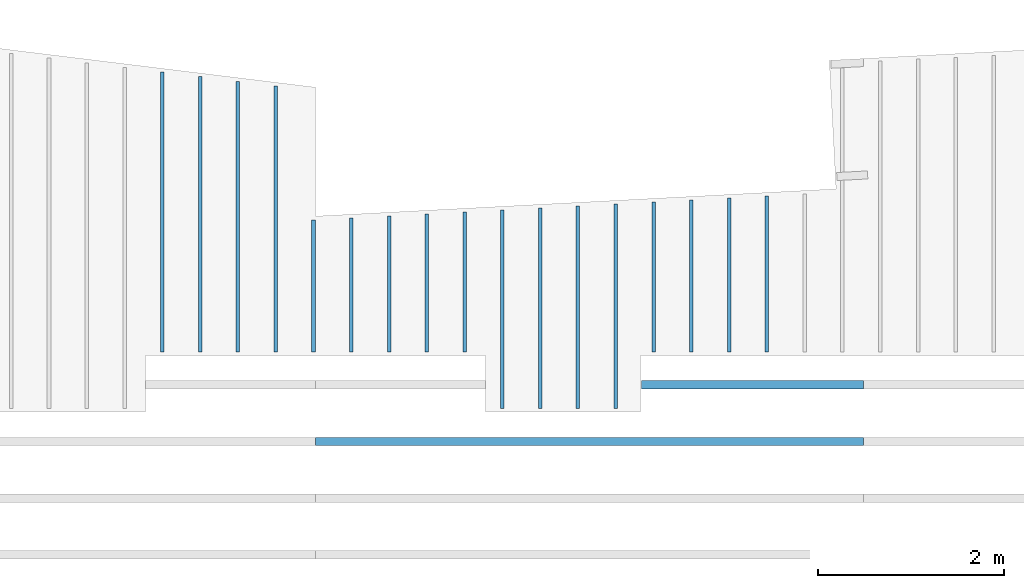
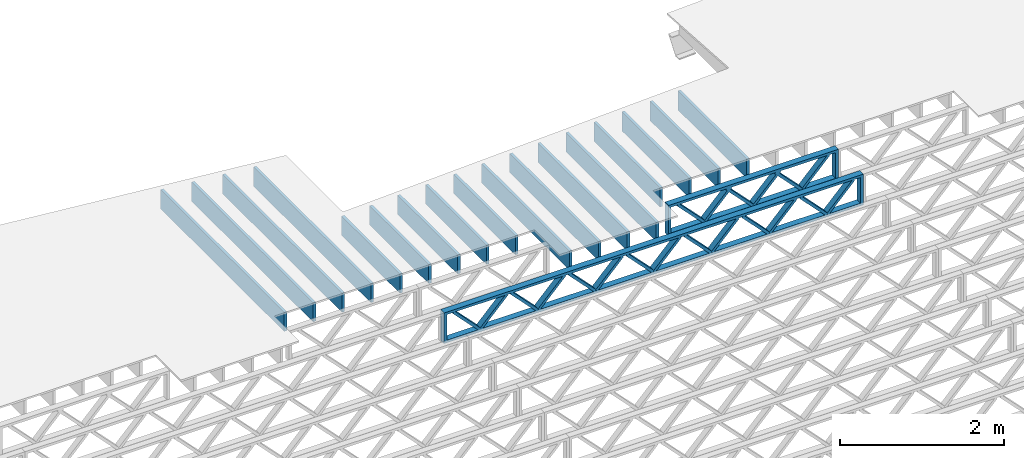
# One storey, part 10 of 13: 19 beams, 2 elements without a shape of their own.
"""IFC4 building model written with IfcOpenShell, lengths in feet."""

from ifc_helpers import new_model, entity, si_unit, converted_unit, derived_unit, direction, frame, frame_2d, origin, origin_2d_with_axis, place, context, subcontext, project, spatial, rectangle, extrude, source, transform, mapped, material, material_profile, profile_set, profile_usage, type_object, type_shapes, element, aggregate, save


model = new_model("IFC4")

# Units and contexts
model_context_1 = context("Model", 3, precision=0.0001, world=origin(), true_north=direction((6.12303176911189e-17, 1.0)))
model_context_2 = context("Model", 3, precision=0.0001, world=origin(), true_north=direction((6.12303176911189e-17, 1.0)))
body_context = subcontext(model_context_2, "Body", "Model", "MODEL_VIEW")
ifc_project = project(units=[converted_unit("LENGTHUNIT", "FOOT", entity("IfcRatioMeasure", 0.3048), si_unit("LENGTHUNIT", "METRE"), dimensions=[1, 0, 0, 0, 0, 0, 0]), converted_unit("AREAUNIT", "SQUARE FOOT", entity("IfcRatioMeasure", 0.09290304), si_unit("AREAUNIT", "SQUARE_METRE"), dimensions=[2, 0, 0, 0, 0, 0, 0]), converted_unit("VOLUMEUNIT", "CUBIC FOOT", entity("IfcRatioMeasure", 0.028316846592), si_unit("VOLUMEUNIT", "CUBIC_METRE"), dimensions=[3, 0, 0, 0, 0, 0, 0]), converted_unit("PLANEANGLEUNIT", "DEGREE", entity("IfcRatioMeasure", 0.0174532925199433), si_unit("PLANEANGLEUNIT", "RADIAN"), dimensions=[0, 0, 0, 0, 0, 0, 0]), si_unit("MASSUNIT", "GRAM", prefix="KILO"), derived_unit("MASSDENSITYUNIT", [(si_unit("MASSUNIT", "GRAM", prefix="KILO"), 1), (si_unit("LENGTHUNIT", "METRE"), -3)]), derived_unit("MOMENTOFINERTIAUNIT", [(si_unit("LENGTHUNIT", "METRE"), 4)]), si_unit("TIMEUNIT", "SECOND"), si_unit("FREQUENCYUNIT", "HERTZ"), si_unit("THERMODYNAMICTEMPERATUREUNIT", "DEGREE_CELSIUS"), derived_unit("THERMALTRANSMITTANCEUNIT", [(si_unit("MASSUNIT", "GRAM", prefix="KILO"), 1), (si_unit("THERMODYNAMICTEMPERATUREUNIT", "KELVIN"), -1), (si_unit("TIMEUNIT", "SECOND"), -3)]), derived_unit("VOLUMETRICFLOWRATEUNIT", [(si_unit("LENGTHUNIT", "METRE"), 3), (si_unit("TIMEUNIT", "SECOND"), -1)]), si_unit("ELECTRICCURRENTUNIT", "AMPERE"), si_unit("ELECTRICVOLTAGEUNIT", "VOLT"), si_unit("POWERUNIT", "WATT"), si_unit("FORCEUNIT", "NEWTON"), si_unit("ILLUMINANCEUNIT", "LUX"), si_unit("LUMINOUSFLUXUNIT", "LUMEN"), si_unit("LUMINOUSINTENSITYUNIT", "CANDELA"), derived_unit("USERDEFINED", [(si_unit("MASSUNIT", "GRAM", prefix="KILO"), -1), (si_unit("LENGTHUNIT", "METRE"), -2), (si_unit("TIMEUNIT", "SECOND"), 3), (si_unit("LUMINOUSFLUXUNIT", "LUMEN"), 1)]), derived_unit("LINEARVELOCITYUNIT", [(si_unit("LENGTHUNIT", "METRE"), 1), (si_unit("TIMEUNIT", "SECOND"), -1)]), si_unit("PRESSUREUNIT", "PASCAL"), derived_unit("USERDEFINED", [(si_unit("LENGTHUNIT", "METRE"), -2), (si_unit("MASSUNIT", "GRAM", prefix="KILO"), 1), (si_unit("TIMEUNIT", "SECOND"), -2)]), derived_unit("LINEARFORCEUNIT", [(si_unit("MASSUNIT", "GRAM", prefix="KILO"), 1), (si_unit("LENGTHUNIT", "METRE"), 1), (si_unit("TIMEUNIT", "SECOND"), -2), (si_unit("LENGTHUNIT", "METRE"), -1)]), derived_unit("PLANARFORCEUNIT", [(si_unit("MASSUNIT", "GRAM", prefix="KILO"), 1), (si_unit("LENGTHUNIT", "METRE"), 1), (si_unit("TIMEUNIT", "SECOND"), -2), (si_unit("LENGTHUNIT", "METRE"), -2)])], contexts=[model_context_1])

# Site, building, storey
site_placement = place(None, origin())
site = spatial("IfcSite", under=ifc_project, at=site_placement, CompositionType="ELEMENT")
building_placement = place(site_placement, origin())
building = spatial("IfcBuilding", under=site, at=building_placement, CompositionType="ELEMENT")
storey_placement = place(building_placement, frame((0.0, 0.0, 21.46875)))
storey = spatial("IfcBuildingStorey", under=building, at=storey_placement, Name="3RD FLOOR", CompositionType="ELEMENT", Elevation=21.46875)

# Assembly, beams
assembly_1_placement = place(storey_placement, origin())
assembly_1 = element("IfcElementAssembly", 1, at=assembly_1_placement, inside=storey, Name="Structural Beam System:Structural Framing System", ObjectType="Structural Beam System:Structural Framing System", AssemblyPlace="NOTDEFINED", PredefinedType="BEAM_GRID")
ifc_material_1 = material(Name="WOOD TRUSS", Category="Materials")
ifc_material_profile_1 = material_profile(ifc_material_1, rectangle(XDim=1.73473973950632, YDim=0.125, at=frame_2d((-1.11022302462516e-16, 8.32667268468867e-17), x_axis=(1.0, 0.0))))
ifc_material_profile_2 = material_profile(ifc_material_1, rectangle(XDim=1.73473973950633, YDim=0.125, at=frame_2d((-1.11022302462516e-16, 8.32667268468867e-17), x_axis=(1.0, 0.0))))
ifc_material_profile_3 = material_profile(ifc_material_1, rectangle(XDim=1.73473973950632, YDim=0.125, at=frame_2d((-5.55111512312578e-17, 1.38777878078145e-16), x_axis=(1.0, 0.0))))
ifc_material_profile_4 = material_profile(ifc_material_1, rectangle(XDim=1.73473973950633, YDim=0.125, at=frame_2d((-1.11022302462516e-16, 8.32667268468867e-17), x_axis=(1.0, 0.0))))
ifc_material_profile_5 = material_profile(ifc_material_1, rectangle(XDim=1.73473973950632, YDim=0.125, at=frame_2d((-1.11022302462516e-16, 8.32667268468867e-17), x_axis=(1.0, 0.0))))
ifc_material_profile_6 = material_profile(ifc_material_1, rectangle(XDim=1.73473973950633, YDim=0.125, at=frame_2d((-2.77555756156289e-16, 3.05311331771918e-16), x_axis=(1.0, 0.0))))
ifc_material_profile_7 = material_profile(ifc_material_1, rectangle(XDim=1.73473973950632, YDim=0.124999999999999, at=frame_2d((-3.88578058618805e-16, -2.4980018054066e-16), x_axis=(1.0, 0.0))))
ifc_material_profile_8 = material_profile(ifc_material_1, rectangle(XDim=1.73473973950633, YDim=0.125, at=frame_2d((2.77555756156289e-16, -3.05311331771918e-16), x_axis=(1.0, 0.0))))
ifc_material_profile_9 = material_profile(ifc_material_1, rectangle(XDim=1.73473973950632, YDim=0.124999999999999, at=frame_2d((-1.11022302462516e-16, 8.32667268468867e-17), x_axis=(1.0, 0.0))))
ifc_material_profile_10 = material_profile(ifc_material_1, rectangle(XDim=1.73473973950633, YDim=0.125, at=origin_2d_with_axis()))
ifc_material_profile_11 = material_profile(ifc_material_1, rectangle(XDim=0.124999999999982, YDim=0.291666666666668, at=origin_2d_with_axis()))
ifc_material_profile_12 = material_profile(ifc_material_1, rectangle(XDim=0.124999999999932, YDim=0.291666666666664, at=origin_2d_with_axis()))
ifc_material_profile_13 = material_profile(ifc_material_1, rectangle(XDim=1.25000000000002, YDim=0.29166666666667, at=origin_2d_with_axis()))
ifc_material_profile_14 = material_profile(ifc_material_1, rectangle(XDim=1.25000000000004, YDim=0.291666666666667, at=origin_2d_with_axis()))
ifc_profile_set_1 = profile_set([ifc_material_profile_1, ifc_material_profile_2, ifc_material_profile_3, ifc_material_profile_4, ifc_material_profile_5, ifc_material_profile_6, ifc_material_profile_7, ifc_material_profile_8, ifc_material_profile_9, ifc_material_profile_10, ifc_material_profile_11, ifc_material_profile_12, ifc_material_profile_13, ifc_material_profile_14])
ifc_profile_usage_1 = profile_usage(ifc_profile_set_1, cardinal=8)
beam_type_1 = type_object("IfcBeamType", PredefinedType="BEAM", material=ifc_profile_set_1)
shared_shape_1 = source(origin(), body_context, "Body", "SweptSolid", [
    extrude(rectangle(XDim=1.73473973950632, YDim=0.124999999999999, at=frame_2d((5.55111512312578e-16, 7.21644966006352e-16), x_axis=(1.0, 0.0))), frame((5.95847627016997, -0.145833333333334, 0.0), z_axis=(0.0, 1.0, 0.0), x_axis=(0.693383046997606, 0.0, 0.720569184836762)), (0.0, 0.0, 1.0), 0.291666666666667),
    extrude(rectangle(XDim=1.73473973950633, YDim=0.125, at=origin_2d_with_axis()), frame((4.7081903964967, -0.145833333333334, 0.0), z_axis=(0.0, 1.0, 0.0), x_axis=(0.69338304699761, 0.0, -0.720569184836758)), (0.0, 0.0, 1.0), 0.291666666666666),
    extrude(rectangle(XDim=1.73473973950632, YDim=0.125, at=frame_2d((2.22044604925031e-16, 3.88578058618805e-16), x_axis=(1.0, 0.0))), frame((3.29180960350347, -0.145833333333334, 0.0), z_axis=(0.0, 1.0, 0.0), x_axis=(0.693383046997606, 0.0, 0.720569184836762)), (0.0, 0.0, 1.0), 0.291666666666667),
    extrude(rectangle(XDim=1.73473973950633, YDim=0.125, at=frame_2d((1.11022302462516e-16, -8.32667268468867e-17), x_axis=(1.0, 0.0))), frame((2.0415237298302, -0.145833333333334, 0.0), z_axis=(0.0, 1.0, 0.0), x_axis=(0.69338304699761, 0.0, -0.720569184836758)), (0.0, 0.0, 1.0), 0.291666666666667),
    extrude(rectangle(XDim=1.73473973950632, YDim=0.125, at=frame_2d((-5.55111512312578e-17, 1.38777878078145e-16), x_axis=(1.0, 0.0))), frame((0.625142936836964, -0.145833333333334, 0.0), z_axis=(0.0, 1.0, 0.0), x_axis=(0.693383046997606, 0.0, 0.720569184836762)), (0.0, 0.0, 1.0), 0.291666666666667),
    extrude(rectangle(XDim=1.73473973950633, YDim=0.125, at=frame_2d((-1.11022302462516e-16, 8.32667268468867e-17), x_axis=(1.0, 0.0))), frame((-0.625142936836306, -0.145833333333334, 0.0), z_axis=(0.0, 1.0, 0.0), x_axis=(0.69338304699761, 0.0, -0.720569184836758)), (0.0, 0.0, 1.0), 0.291666666666667),
    extrude(rectangle(XDim=1.73473973950632, YDim=0.125, at=frame_2d((-1.11022302462516e-16, 8.32667268468867e-17), x_axis=(1.0, 0.0))), frame((-2.04152372982954, -0.145833333333334, 0.0), z_axis=(0.0, 1.0, 0.0), x_axis=(0.693383046997606, 0.0, 0.720569184836762)), (0.0, 0.0, 1.0), 0.291666666666667),
    extrude(rectangle(XDim=1.73473973950633, YDim=0.125, at=origin_2d_with_axis()), frame((-3.29180960350281, -0.145833333333334, 0.0), z_axis=(0.0, 1.0, 0.0), x_axis=(0.69338304699761, 0.0, -0.720569184836758)), (0.0, 0.0, 1.0), 0.291666666666667),
    extrude(rectangle(XDim=1.73473973950632, YDim=0.124999999999999, at=frame_2d((-1.11022302462516e-16, 8.32667268468867e-17), x_axis=(1.0, 0.0))), frame((-4.70819039649604, -0.145833333333334, 0.0), z_axis=(0.0, 1.0, 0.0), x_axis=(0.693383046997606, 0.0, 0.720569184836762)), (0.0, 0.0, 1.0), 0.291666666666667),
    extrude(rectangle(XDim=1.73473973950633, YDim=0.125, at=frame_2d((-5.55111512312578e-16, 6.38378239159465e-16), x_axis=(1.0, 0.0))), frame((-5.95847627016931, -0.145833333333334, 0.0), z_axis=(0.0, 1.0, 0.0), x_axis=(0.69338304699761, 0.0, -0.720569184836758)), (0.0, 0.0, 1.0), 0.291666666666666),
    extrude(rectangle(XDim=1.73473973950632, YDim=0.125, at=frame_2d((-7.21644966006352e-16, -5.82867087928207e-16), x_axis=(1.0, 0.0))), frame((8.62514293683647, -0.145833333333334, 0.0), z_axis=(0.0, 1.0, 0.0), x_axis=(0.693383046997607, 0.0, 0.720569184836761)), (0.0, 0.0, 1.0), 0.291666666666667),
    extrude(rectangle(XDim=1.73473973950633, YDim=0.125, at=origin_2d_with_axis()), frame((7.3748570631632, -0.145833333333334, 0.0), z_axis=(0.0, 1.0, 0.0), x_axis=(0.69338304699761, 0.0, -0.720569184836758)), (0.0, 0.0, 1.0), 0.291666666666666),
    extrude(rectangle(XDim=1.73473973950632, YDim=0.124999999999999, at=frame_2d((-1.11022302462516e-16, 8.32667268468867e-17), x_axis=(1.0, 0.0))), frame((-7.37485706316255, -0.145833333333334, 0.0), z_axis=(0.0, 1.0, 0.0), x_axis=(0.693383046997606, 0.0, 0.720569184836762)), (0.0, 0.0, 1.0), 0.291666666666667),
    extrude(rectangle(XDim=1.73473973950633, YDim=0.125, at=origin_2d_with_axis()), frame((-8.62514293683582, -0.145833333333334, 0.0), z_axis=(0.0, 1.0, 0.0), x_axis=(0.69338304699761, 0.0, -0.720569184836758)), (0.0, 0.0, 1.0), 0.291666666666666),
    extrude(rectangle(XDim=0.124999999999982, YDim=0.291666666666668, at=origin_2d_with_axis()), frame((-9.66666666666609, 0.0, 0.687500000000054), z_axis=(1.0, 0.0, 0.0), x_axis=(0.0, 0.0, -1.0)), (0.0, 0.0, 1.0), 19.3333333333322),
    extrude(rectangle(XDim=0.124999999999932, YDim=0.291666666666664, at=origin_2d_with_axis()), frame((-9.66666666666588, 0.0, -0.687499999999984), z_axis=(1.0, 0.0, 0.0), x_axis=(0.0, 0.0, -1.0)), (0.0, 0.0, 1.0), 19.333333333332),
    extrude(rectangle(XDim=1.25000000000002, YDim=0.29166666666667, at=origin_2d_with_axis()), frame((9.54166666666607, 0.0, 0.0), z_axis=(1.0, 0.0, 0.0), x_axis=(0.0, 0.0, -1.0)), (0.0, 0.0, 1.0), 0.12500000000002),
    extrude(rectangle(XDim=1.25000000000004, YDim=0.291666666666667, at=origin_2d_with_axis()), frame((-9.66666666666609, 0.0, 0.0), z_axis=(1.0, 0.0, 0.0), x_axis=(0.0, 0.0, -1.0)), (0.0, 0.0, 1.0), 0.125000000000023),
])
type_shapes(beam_type_1, [shared_shape_1])
beam_1_placement = place(assembly_1_placement, frame((-174.071493818896, 955.861934882651, -0.947916666666661), z_axis=(0.0, 0.0, 1.0), x_axis=(-1.0, 0.0, 0.0)))
beam_1 = element("IfcBeam", 2, at=beam_1_placement, type_object=beam_type_1, material=ifc_profile_usage_1, PredefinedType="BEAM", context=body_context, shape_type="MappedRepresentation", body=[
    mapped(shared_shape_1, transform((0.0, 0.0, 0.0), scale=1.0)),
])
ifc_profile_usage_2 = profile_usage(ifc_profile_set_1, cardinal=8)
beam_type_2 = type_object("IfcBeamType", PredefinedType="BEAM", material=ifc_profile_set_1)
shared_shape_2 = source(origin(), body_context, "Body", "SweptSolid", [
    extrude(rectangle(XDim=1.73473973950632, YDim=0.125, at=frame_2d((-5.55111512312578e-17, 1.38777878078145e-16), x_axis=(1.0, 0.0))), frame((0.625142936836962, -0.145833333333334, 0.0), z_axis=(0.0, 1.0, 0.0), x_axis=(0.693383046997606, 0.0, 0.720569184836762)), (0.0, 0.0, 1.0), 0.291666666666667),
    extrude(rectangle(XDim=1.73473973950633, YDim=0.125, at=frame_2d((-1.11022302462516e-16, 8.32667268468867e-17), x_axis=(1.0, 0.0))), frame((-0.625142936836309, -0.145833333333334, 0.0), z_axis=(0.0, 1.0, 0.0), x_axis=(0.69338304699761, 0.0, -0.720569184836758)), (0.0, 0.0, 1.0), 0.291666666666667),
    extrude(rectangle(XDim=1.73473973950632, YDim=0.125, at=frame_2d((-1.11022302462516e-16, 8.32667268468867e-17), x_axis=(1.0, 0.0))), frame((2.87514283803796, -0.145833333333334, 0.0), z_axis=(0.0, 1.0, 0.0), x_axis=(0.693383046997606, 0.0, 0.720569184836762)), (0.0, 0.0, 1.0), 0.291666666666667),
    extrude(rectangle(XDim=1.73473973950633, YDim=0.125, at=frame_2d((-1.11022302462516e-16, 8.32667268468867e-17), x_axis=(1.0, 0.0))), frame((1.62485696436469, -0.145833333333334, 0.0), z_axis=(0.0, 1.0, 0.0), x_axis=(0.69338304699761, 0.0, -0.720569184836758)), (0.0, 0.0, 1.0), 0.291666666666667),
    extrude(rectangle(XDim=1.73473973950632, YDim=0.125, at=frame_2d((-1.11022302462516e-16, 8.32667268468867e-17), x_axis=(1.0, 0.0))), frame((-1.62485696436403, -0.145833333333334, 0.0), z_axis=(0.0, 1.0, 0.0), x_axis=(0.693383046997606, 0.0, 0.720569184836762)), (0.0, 0.0, 1.0), 0.291666666666667),
    extrude(rectangle(XDim=1.73473973950633, YDim=0.125, at=origin_2d_with_axis()), frame((-2.87514283803731, -0.145833333333334, 0.0), z_axis=(0.0, 1.0, 0.0), x_axis=(0.69338304699761, 0.0, -0.720569184836758)), (0.0, 0.0, 1.0), 0.291666666666667),
    extrude(rectangle(XDim=0.124999999999982, YDim=0.291666666666668, at=origin_2d_with_axis()), frame((-3.91666656786758, 0.0, 0.687500000000054), z_axis=(1.0, 0.0, 0.0), x_axis=(0.0, 0.0, -1.0)), (0.0, 0.0, 1.0), 7.83333313573516),
    extrude(rectangle(XDim=0.124999999999932, YDim=0.291666666666664, at=origin_2d_with_axis()), frame((-3.91666656786737, 0.0, -0.687499999999984), z_axis=(1.0, 0.0, 0.0), x_axis=(0.0, 0.0, -1.0)), (0.0, 0.0, 1.0), 7.83333313573495),
    extrude(rectangle(XDim=1.25000000000002, YDim=0.29166666666667, at=origin_2d_with_axis()), frame((3.79166656786756, 0.0, 0.0), z_axis=(1.0, 0.0, 0.0), x_axis=(0.0, 0.0, -1.0)), (0.0, 0.0, 1.0), 0.12500000000002),
    extrude(rectangle(XDim=1.25000000000004, YDim=0.291666666666667, at=origin_2d_with_axis()), frame((-3.91666656786758, 0.0, 0.0), z_axis=(1.0, 0.0, 0.0), x_axis=(0.0, 0.0, -1.0)), (0.0, 0.0, 1.0), 0.125000000000023),
])
type_shapes(beam_type_2, [shared_shape_2])
beam_2_placement = place(assembly_1_placement, frame((-168.321493720097, 957.861934882651, -0.947916666666661), z_axis=(0.0, 0.0, 1.0), x_axis=(-1.0, 0.0, 0.0)))
beam_2 = element("IfcBeam", 3, at=beam_2_placement, type_object=beam_type_2, material=ifc_profile_usage_2, PredefinedType="BEAM", context=body_context, shape_type="MappedRepresentation", body=[
    mapped(shared_shape_2, transform((0.0, 0.0, 0.0), scale=1.0)),
])
aggregate(assembly_1, [beam_1, beam_2])

assembly_2_placement = place(storey_placement, origin())
assembly_2 = element("IfcElementAssembly", 4, at=assembly_2_placement, inside=storey, Name="Structural Beam System:Structural Framing System", ObjectType="Structural Beam System:Structural Framing System", AssemblyPlace="NOTDEFINED", PredefinedType="BEAM_GRID")
ifc_material_2 = material(Category="Materials")
ifc_material_profile_15 = material_profile(ifc_material_2, rectangle(XDim=0.9375, YDim=0.125000000000011, at=origin_2d_with_axis()))
ifc_profile_set_2 = profile_set([ifc_material_profile_15])
ifc_profile_usage_3 = profile_usage(ifc_profile_set_2, cardinal=8)
beam_type_3 = type_object("IfcBeamType", PredefinedType="BEAM", material=ifc_profile_set_2)
shared_shape_3 = source(origin(), body_context, "Body", "SweptSolid", [
    extrude(rectangle(XDim=0.9375, YDim=0.125000000000011, at=origin_2d_with_axis()), frame((-2.67761064556333, 0.0, 0.0), z_axis=(1.0, 0.0, 0.0), x_axis=(0.0, 0.0, -1.0)), (0.0, 0.0, 1.0), 5.35522129112667),
])
type_shapes(beam_type_3, [shared_shape_3])
beam_3_placement = place(assembly_2_placement, frame((-170.477622729298, 961.70620862297, -0.729166666666714), z_axis=(0.0, 0.0, 1.0), x_axis=(0.0, 1.0, 0.0)))
beam_3 = element("IfcBeam", 5, at=beam_3_placement, type_object=beam_type_3, material=ifc_profile_usage_3, PredefinedType="BEAM", context=body_context, shape_type="MappedRepresentation", body=[
    mapped(shared_shape_3, transform((0.0, 0.0, 0.0), scale=1.0)),
])
ifc_profile_usage_4 = profile_usage(ifc_profile_set_2, cardinal=8)
beam_type_4 = type_object("IfcBeamType", PredefinedType="BEAM", material=ifc_profile_set_2)
shared_shape_4 = source(origin(), body_context, "Body", "SweptSolid", [
    extrude(rectangle(XDim=0.9375, YDim=0.125000000000011, at=origin_2d_with_axis()), frame((-3.60773348470792, 0.0, 0.0), z_axis=(1.0, 0.0, 0.0), x_axis=(0.0, 0.0, -1.0)), (0.0, 0.0, 1.0), 7.21546696941584),
])
type_shapes(beam_type_4, [shared_shape_4])
beam_4_placement = place(assembly_2_placement, frame((-173.144289395965, 960.636331705738, -0.729166666666714), z_axis=(0.0, 0.0, 1.0), x_axis=(0.0, 1.0, 0.0)))
beam_4 = element("IfcBeam", 6, at=beam_4_placement, type_object=beam_type_4, material=ifc_profile_usage_4, PredefinedType="BEAM", context=body_context, shape_type="MappedRepresentation", body=[
    mapped(shared_shape_4, transform((0.0, 0.0, 0.0), scale=1.0)),
])
ifc_profile_usage_5 = profile_usage(ifc_profile_set_2, cardinal=8)
beam_type_5 = type_object("IfcBeamType", PredefinedType="BEAM", material=ifc_profile_set_2)
shared_shape_5 = source(origin(), body_context, "Body", "SweptSolid", [
    extrude(rectangle(XDim=0.9375, YDim=0.125000000000011, at=origin_2d_with_axis()), frame((-3.57279496518601, 0.0, 0.0), z_axis=(1.0, 0.0, 0.0), x_axis=(0.0, 0.0, -1.0)), (0.0, 0.0, 1.0), 7.14558993037201),
])
type_shapes(beam_type_5, [shared_shape_5])
beam_5_placement = place(assembly_2_placement, frame((-174.477622729298, 960.601393186216, -0.729166666666714), z_axis=(0.0, 0.0, 1.0), x_axis=(0.0, 1.0, 0.0)))
beam_5 = element("IfcBeam", 7, at=beam_5_placement, type_object=beam_type_5, material=ifc_profile_usage_5, PredefinedType="BEAM", context=body_context, shape_type="MappedRepresentation", body=[
    mapped(shared_shape_5, transform((0.0, 0.0, 0.0), scale=1.0)),
])
ifc_profile_usage_6 = profile_usage(ifc_profile_set_2, cardinal=8)
beam_type_6 = type_object("IfcBeamType", PredefinedType="BEAM", material=ifc_profile_set_2)
shared_shape_6 = source(origin(), body_context, "Body", "SweptSolid", [
    extrude(rectangle(XDim=0.9375, YDim=0.125000000000011, at=origin_2d_with_axis()), frame((-3.53785644566409, 0.0, 0.0), z_axis=(1.0, 0.0, 0.0), x_axis=(0.0, 0.0, -1.0)), (0.0, 0.0, 1.0), 7.07571289132818),
])
type_shapes(beam_type_6, [shared_shape_6])
beam_6_placement = place(assembly_2_placement, frame((-175.810956062631, 960.566454666694, -0.729166666666714), z_axis=(0.0, 0.0, 1.0), x_axis=(0.0, 1.0, 0.0)))
beam_6 = element("IfcBeam", 8, at=beam_6_placement, type_object=beam_type_6, material=ifc_profile_usage_6, PredefinedType="BEAM", context=body_context, shape_type="MappedRepresentation", body=[
    mapped(shared_shape_6, transform((0.0, 0.0, 0.0), scale=1.0)),
])
ifc_profile_usage_7 = profile_usage(ifc_profile_set_2, cardinal=8)
beam_type_7 = type_object("IfcBeamType", PredefinedType="BEAM", material=ifc_profile_set_2)
shared_shape_7 = source(origin(), body_context, "Body", "SweptSolid", [
    extrude(rectangle(XDim=0.9375, YDim=0.125000000000011, at=origin_2d_with_axis()), frame((-3.50291792614212, 0.0, 0.0), z_axis=(1.0, 0.0, 0.0), x_axis=(0.0, 0.0, -1.0)), (0.0, 0.0, 1.0), 7.00583585228424),
])
type_shapes(beam_type_7, [shared_shape_7])
beam_7_placement = place(assembly_2_placement, frame((-177.144289395965, 960.531516147172, -0.729166666666714), z_axis=(0.0, 0.0, 1.0), x_axis=(0.0, 1.0, 0.0)))
beam_7 = element("IfcBeam", 9, at=beam_7_placement, type_object=beam_type_7, material=ifc_profile_usage_7, PredefinedType="BEAM", context=body_context, shape_type="MappedRepresentation", body=[
    mapped(shared_shape_7, transform((0.0, 0.0, 0.0), scale=1.0)),
])
ifc_profile_usage_8 = profile_usage(ifc_profile_set_2, cardinal=8)
beam_type_8 = type_object("IfcBeamType", PredefinedType="BEAM", material=ifc_profile_set_2)
shared_shape_8 = source(origin(), body_context, "Body", "SweptSolid", [
    extrude(rectangle(XDim=0.9375, YDim=0.125000000000011, at=origin_2d_with_axis()), frame((-2.32822434331121, 0.0, 0.0), z_axis=(1.0, 0.0, 0.0), x_axis=(0.0, 0.0, -1.0)), (0.0, 0.0, 1.0), 4.6564486846224),
])
type_shapes(beam_type_8, [shared_shape_8])
beam_8_placement = place(assembly_2_placement, frame((-183.810956062631, 961.356824534783, -0.729166666666714), z_axis=(0.0, 0.0, 1.0), x_axis=(0.0, 1.0, 0.0)))
beam_8 = element("IfcBeam", 10, at=beam_8_placement, type_object=beam_type_8, material=ifc_profile_usage_8, PredefinedType="BEAM", context=body_context, shape_type="MappedRepresentation", body=[
    mapped(shared_shape_8, transform((0.0, 0.0, 0.0), scale=1.0)),
])
ifc_profile_usage_9 = profile_usage(ifc_profile_set_2, cardinal=8)
beam_type_9 = type_object("IfcBeamType", PredefinedType="BEAM", material=ifc_profile_set_2)
shared_shape_9 = source(origin(), body_context, "Body", "SweptSolid", [
    extrude(rectangle(XDim=0.9375, YDim=0.125000000000011, at=origin_2d_with_axis()), frame((-4.77186579984931, 0.0, 0.0), z_axis=(1.0, 0.0, 0.0), x_axis=(0.0, 0.0, -1.0)), (0.0, 0.0, 1.0), 9.54373159969862),
])
type_shapes(beam_type_9, [shared_shape_9])
beam_9_placement = place(assembly_2_placement, frame((-186.477622729298, 963.800466661326, -0.729166666666714), z_axis=(0.0, 0.0, 1.0), x_axis=(0.0, 1.0, 0.0)))
beam_9 = element("IfcBeam", 11, at=beam_9_placement, type_object=beam_type_9, material=ifc_profile_usage_9, PredefinedType="BEAM", context=body_context, shape_type="MappedRepresentation", body=[
    mapped(shared_shape_9, transform((0.0, 0.0, 0.0), scale=1.0)),
])
ifc_profile_usage_10 = profile_usage(ifc_profile_set_2, cardinal=8)
beam_type_10 = type_object("IfcBeamType", PredefinedType="BEAM", material=ifc_profile_set_2)
shared_shape_10 = source(origin(), body_context, "Body", "SweptSolid", [
    extrude(rectangle(XDim=0.9375, YDim=0.125000000000011, at=origin_2d_with_axis()), frame((-4.85372200628331, 0.0, 0.0), z_axis=(1.0, 0.0, 0.0), x_axis=(0.0, 0.0, -1.0)), (0.0, 0.0, 1.0), 9.70744401256661),
])
type_shapes(beam_type_10, [shared_shape_10])
beam_10_placement = place(assembly_2_placement, frame((-187.810956062631, 963.882323202763, -0.729166666666714), z_axis=(0.0, 0.0, 1.0), x_axis=(0.0, 1.0, 0.0)))
beam_10 = element("IfcBeam", 12, at=beam_10_placement, type_object=beam_type_10, material=ifc_profile_usage_10, PredefinedType="BEAM", context=body_context, shape_type="MappedRepresentation", body=[
    mapped(shared_shape_10, transform((0.0, 0.0, 0.0), scale=1.0)),
])
ifc_profile_usage_11 = profile_usage(ifc_profile_set_2, cardinal=8)
beam_type_11 = type_object("IfcBeamType", PredefinedType="BEAM", material=ifc_profile_set_2)
shared_shape_11 = source(origin(), body_context, "Body", "SweptSolid", [
    extrude(rectangle(XDim=0.9375, YDim=0.125000000000011, at=origin_2d_with_axis()), frame((-4.93557821271736, 0.0, 0.0), z_axis=(1.0, 0.0, 0.0), x_axis=(0.0, 0.0, -1.0)), (0.0, 0.0, 1.0), 9.87115642543472),
])
type_shapes(beam_type_11, [shared_shape_11])
beam_11_placement = place(assembly_2_placement, frame((-189.144289395965, 963.964179744199, -0.729166666666714), z_axis=(0.0, 0.0, 1.0), x_axis=(0.0, 1.0, 0.0)))
beam_11 = element("IfcBeam", 13, at=beam_11_placement, type_object=beam_type_11, material=ifc_profile_usage_11, PredefinedType="BEAM", context=body_context, shape_type="MappedRepresentation", body=[
    mapped(shared_shape_11, transform((0.0, 0.0, 0.0), scale=1.0)),
])
ifc_profile_usage_12 = profile_usage(ifc_profile_set_2, cardinal=8)
beam_type_12 = type_object("IfcBeamType", PredefinedType="BEAM", material=ifc_profile_set_2)
shared_shape_12 = source(origin(), body_context, "Body", "SweptSolid", [
    extrude(rectangle(XDim=0.9375, YDim=0.125000000000011, at=origin_2d_with_axis()), frame((-4.69000959341525, 0.0, 0.0), z_axis=(1.0, 0.0, 0.0), x_axis=(0.0, 0.0, -1.0)), (0.0, 0.0, 1.0), 9.38001918683051),
])
type_shapes(beam_type_12, [shared_shape_12])
beam_12_placement = place(assembly_2_placement, frame((-185.144289395965, 963.71861011989, -0.729166666666714), z_axis=(0.0, 0.0, 1.0), x_axis=(0.0, 1.0, 0.0)))
beam_12 = element("IfcBeam", 14, at=beam_12_placement, type_object=beam_type_12, material=ifc_profile_usage_12, PredefinedType="BEAM", context=body_context, shape_type="MappedRepresentation", body=[
    mapped(shared_shape_12, transform((0.0, 0.0, 0.0), scale=1.0)),
])
ifc_profile_usage_13 = profile_usage(ifc_profile_set_2, cardinal=8)
beam_type_13 = type_object("IfcBeamType", PredefinedType="BEAM", material=ifc_profile_set_2)
shared_shape_13 = source(origin(), body_context, "Body", "SweptSolid", [
    extrude(rectangle(XDim=0.9375, YDim=0.125000000000011, at=origin_2d_with_axis()), frame((-2.36316303033436, 0.0, 0.0), z_axis=(1.0, 0.0, 0.0), x_axis=(0.0, 0.0, -1.0)), (0.0, 0.0, 1.0), 4.72632606066873),
])
type_shapes(beam_type_13, [shared_shape_13])
beam_13_placement = place(assembly_2_placement, frame((-182.477622729298, 961.391762886804, -0.729166666666714), z_axis=(0.0, 0.0, 1.0), x_axis=(0.0, 1.0, 0.0)))
beam_13 = element("IfcBeam", 15, at=beam_13_placement, type_object=beam_type_13, material=ifc_profile_usage_13, PredefinedType="BEAM", context=body_context, shape_type="MappedRepresentation", body=[
    mapped(shared_shape_13, transform((0.0, 0.0, 0.0), scale=1.0)),
])
ifc_profile_usage_14 = profile_usage(ifc_profile_set_2, cardinal=8)
beam_type_14 = type_object("IfcBeamType", PredefinedType="BEAM", material=ifc_profile_set_2)
shared_shape_14 = source(origin(), body_context, "Body", "SweptSolid", [
    extrude(rectangle(XDim=0.9375, YDim=0.125000000000011, at=origin_2d_with_axis()), frame((-2.39810171735763, 0.0, 0.0), z_axis=(1.0, 0.0, 0.0), x_axis=(0.0, 0.0, -1.0)), (0.0, 0.0, 1.0), 4.79620343471527),
])
type_shapes(beam_type_14, [shared_shape_14])
beam_14_placement = place(assembly_2_placement, frame((-181.144289395965, 961.426701238825, -0.729166666666714), z_axis=(0.0, 0.0, 1.0), x_axis=(0.0, 1.0, 0.0)))
beam_14 = element("IfcBeam", 16, at=beam_14_placement, type_object=beam_type_14, material=ifc_profile_usage_14, PredefinedType="BEAM", context=body_context, shape_type="MappedRepresentation", body=[
    mapped(shared_shape_14, transform((0.0, 0.0, 0.0), scale=1.0)),
])
ifc_profile_usage_15 = profile_usage(ifc_profile_set_2, cardinal=8)
beam_type_15 = type_object("IfcBeamType", PredefinedType="BEAM", material=ifc_profile_set_2)
shared_shape_15 = source(origin(), body_context, "Body", "SweptSolid", [
    extrude(rectangle(XDim=0.9375, YDim=0.125000000000011, at=origin_2d_with_axis()), frame((-2.43304040438079, 0.0, 0.0), z_axis=(1.0, 0.0, 0.0), x_axis=(0.0, 0.0, -1.0)), (0.0, 0.0, 1.0), 4.86608080876158),
])
type_shapes(beam_type_15, [shared_shape_15])
beam_15_placement = place(assembly_2_placement, frame((-179.810956062631, 961.461639590845, -0.729166666666714), z_axis=(0.0, 0.0, 1.0), x_axis=(0.0, 1.0, 0.0)))
beam_15 = element("IfcBeam", 17, at=beam_15_placement, type_object=beam_type_15, material=ifc_profile_usage_15, PredefinedType="BEAM", context=body_context, shape_type="MappedRepresentation", body=[
    mapped(shared_shape_15, transform((0.0, 0.0, 0.0), scale=1.0)),
])
ifc_profile_usage_16 = profile_usage(ifc_profile_set_2, cardinal=8)
beam_type_16 = type_object("IfcBeamType", PredefinedType="BEAM", material=ifc_profile_set_2)
shared_shape_16 = source(origin(), body_context, "Body", "SweptSolid", [
    extrude(rectangle(XDim=0.9375, YDim=0.125000000000011, at=origin_2d_with_axis()), frame((-2.467979091404, 0.0, 0.0), z_axis=(1.0, 0.0, 0.0), x_axis=(0.0, 0.0, -1.0)), (0.0, 0.0, 1.0), 4.93595818280801),
])
type_shapes(beam_type_16, [shared_shape_16])
beam_16_placement = place(assembly_2_placement, frame((-178.477622729298, 961.496577942866, -0.729166666666714), z_axis=(0.0, 0.0, 1.0), x_axis=(0.0, 1.0, 0.0)))
beam_16 = element("IfcBeam", 18, at=beam_16_placement, type_object=beam_type_16, material=ifc_profile_usage_16, PredefinedType="BEAM", context=body_context, shape_type="MappedRepresentation", body=[
    mapped(shared_shape_16, transform((0.0, 0.0, 0.0), scale=1.0)),
])
ifc_profile_usage_17 = profile_usage(ifc_profile_set_2, cardinal=8)
beam_type_17 = type_object("IfcBeamType", PredefinedType="BEAM", material=ifc_profile_set_2)
shared_shape_17 = source(origin(), body_context, "Body", "SweptSolid", [
    extrude(rectangle(XDim=0.9375, YDim=0.125000000000011, at=origin_2d_with_axis()), frame((-2.64267229354266, 0.0, 0.0), z_axis=(1.0, 0.0, 0.0), x_axis=(0.0, 0.0, -1.0)), (0.0, 0.0, 1.0), 5.28534458708532),
])
type_shapes(beam_type_17, [shared_shape_17])
beam_17_placement = place(assembly_2_placement, frame((-171.810956062631, 961.671269935947, -0.729166666666714), z_axis=(0.0, 0.0, 1.0), x_axis=(0.0, 1.0, 0.0)))
beam_17 = element("IfcBeam", 19, at=beam_17_placement, type_object=beam_type_17, material=ifc_profile_usage_17, PredefinedType="BEAM", context=body_context, shape_type="MappedRepresentation", body=[
    mapped(shared_shape_17, transform((0.0, 0.0, 0.0), scale=1.0)),
])
ifc_profile_usage_18 = profile_usage(ifc_profile_set_2, cardinal=8)
beam_type_18 = type_object("IfcBeamType", PredefinedType="BEAM", material=ifc_profile_set_2)
shared_shape_18 = source(origin(), body_context, "Body", "SweptSolid", [
    extrude(rectangle(XDim=0.9375, YDim=0.125000000000011, at=origin_2d_with_axis()), frame((-2.71254899758407, 0.0, 0.0), z_axis=(1.0, 0.0, 0.0), x_axis=(0.0, 0.0, -1.0)), (0.0, 0.0, 1.0), 5.42509799516813),
])
type_shapes(beam_type_18, [shared_shape_18])
beam_18_placement = place(assembly_2_placement, frame((-169.144289395965, 961.741147309993, -0.729166666666714), z_axis=(0.0, 0.0, 1.0), x_axis=(0.0, 1.0, 0.0)))
beam_18 = element("IfcBeam", 20, at=beam_18_placement, type_object=beam_type_18, material=ifc_profile_usage_18, PredefinedType="BEAM", context=body_context, shape_type="MappedRepresentation", body=[
    mapped(shared_shape_18, transform((0.0, 0.0, 0.0), scale=1.0)),
])
ifc_profile_usage_19 = profile_usage(ifc_profile_set_2, cardinal=8)
beam_type_19 = type_object("IfcBeamType", PredefinedType="BEAM", material=ifc_profile_set_2)
shared_shape_19 = source(origin(), body_context, "Body", "SweptSolid", [
    extrude(rectangle(XDim=0.9375, YDim=0.125000000000011, at=origin_2d_with_axis()), frame((-2.74748734960474, 0.0, 0.0), z_axis=(1.0, 0.0, 0.0), x_axis=(0.0, 0.0, -1.0)), (0.0, 0.0, 1.0), 5.49497469920948),
])
type_shapes(beam_type_19, [shared_shape_19])
beam_19_placement = place(assembly_2_placement, frame((-167.810956062631, 961.776085997016, -0.729166666666714), z_axis=(0.0, 0.0, 1.0), x_axis=(0.0, 1.0, 0.0)))
beam_19 = element("IfcBeam", 21, at=beam_19_placement, type_object=beam_type_19, material=ifc_profile_usage_19, PredefinedType="BEAM", context=body_context, shape_type="MappedRepresentation", body=[
    mapped(shared_shape_19, transform((0.0, 0.0, 0.0), scale=1.0)),
])
aggregate(assembly_2, [beam_3, beam_4, beam_5, beam_6, beam_7, beam_8, beam_9, beam_10, beam_11, beam_12, beam_13, beam_14, beam_15, beam_16, beam_17, beam_18, beam_19])

save(model, "model.ifc")
